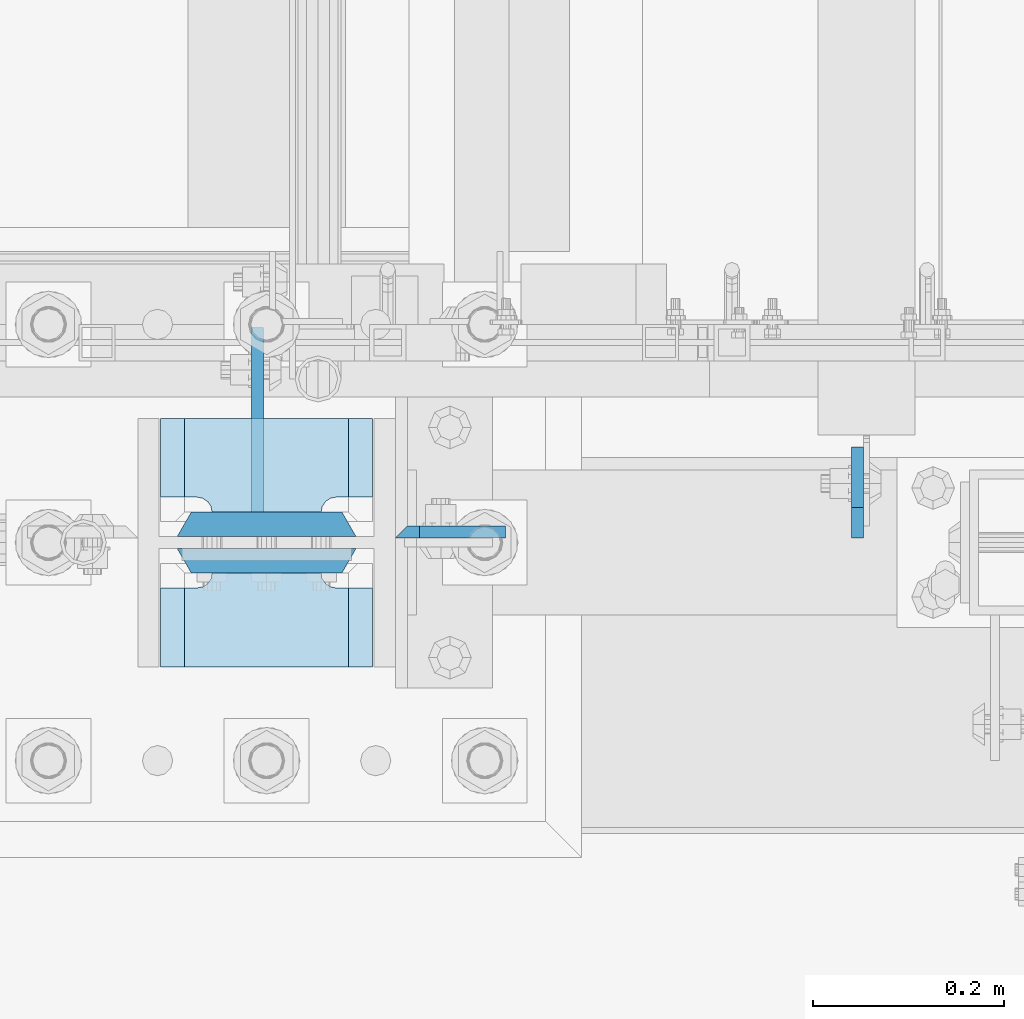
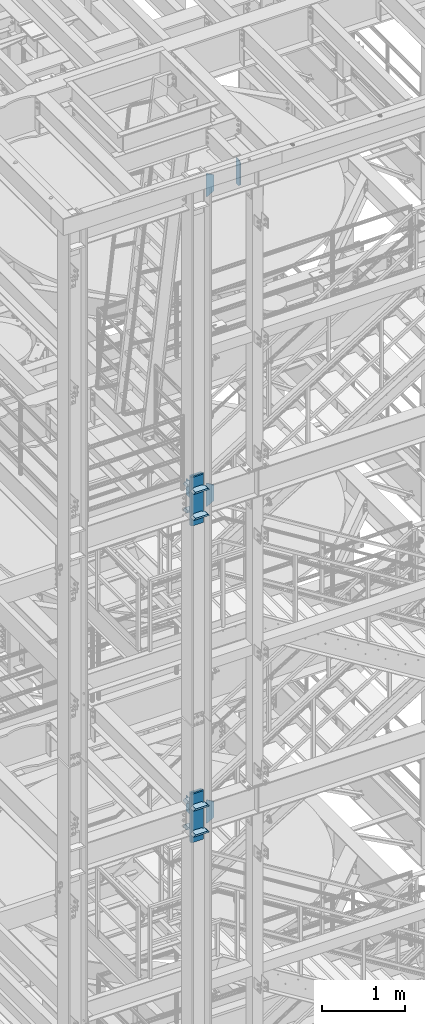
# One storey, part 1435 of 1876: 18 plates, 3 elements without a shape of their own.
"""IFC2X3 building model written with IfcOpenShell, lengths in millimetres."""

from ifc_helpers import new_model, si_unit, frame, origin_with_axes, place, context, subcontext, project, spatial, faceted_brep, material, type_object, element, aggregate, save


model = new_model("IFC2X3")

# Units and contexts
model_context = context("Model", 3, precision=1e-05, world=origin_with_axes())
body_context = subcontext(model_context, "Body", "Model", "MODEL_VIEW")
ifc_project = project(units=[si_unit("LENGTHUNIT", "METRE", prefix="MILLI"), si_unit("AREAUNIT", "SQUARE_METRE"), si_unit("VOLUMEUNIT", "CUBIC_METRE"), si_unit("MASSUNIT", "GRAM", prefix="KILO"), si_unit("TIMEUNIT", "SECOND"), si_unit("PLANEANGLEUNIT", "RADIAN"), si_unit("SOLIDANGLEUNIT", "STERADIAN"), si_unit("THERMODYNAMICTEMPERATUREUNIT", "DEGREE_CELSIUS"), si_unit("LUMINOUSINTENSITYUNIT", "LUMEN")], contexts=[model_context])

# Site, building, storey
site_placement = place(None, origin_with_axes())
site = spatial("IfcSite", under=ifc_project, at=site_placement, CompositionType="ELEMENT")
building_placement = place(site_placement, origin_with_axes())
building = spatial("IfcBuilding", under=site, at=building_placement, Name="Undefined", CompositionType="ELEMENT")
storey_placement = place(building_placement, origin_with_axes())
storey = spatial("IfcBuildingStorey", under=building, at=storey_placement, Name="Undefined", CompositionType="ELEMENT", Elevation=0.0)

# Assembly, plates
assembly_1_placement = place(storey_placement, origin_with_axes())
assembly_1 = element("IfcElementAssembly", 1, at=assembly_1_placement, inside=storey, Name="COLUMN", AssemblyPlace="NOTDEFINED", PredefinedType="RIGID_FRAME")
ifc_material_1 = material(Name="STEEL/A572-50")
plate_type_1 = type_object("IfcPlateType", PredefinedType="NOTDEFINED")
plate_1_placement = place(assembly_1_placement, frame((1862.1375, -7100.88799991608, 17946.6875), z_axis=(1.0, 0.0, 0.0), x_axis=(0.0, 0.0, -1.0)))
plate_1 = element("IfcPlate", 2, at=plate_1_placement, type_object=plate_type_1, material=ifc_material_1, Name="PLATE", context=body_context, shape_type="Brep", body=[
    faceted_brep([(0.0, -6.35000000000036, 0.0), (-1.06936913171421e-12, 6.34999999999945, 12.699999332428), (336.549987792969, 6.35000000000036, 12.7), (336.549987792969, -6.35000000000036, 0.0), (336.550000000001, -6.35000000000036, 25.4000000000005), (336.549987792969, 6.35000000000036, 25.4000000000005), (284.53616791736, 6.35000000000036, 115.490600585938), (284.53616791736, -6.35000000000036, 115.490600307004), (52.0138320922852, -6.35000000000036, 115.490599060059), (52.0138320922852, 6.35000000000036, 115.490600585938), (0.0, 6.35000000000036, 25.4000000000005), (0.0, -6.35000000000036, 25.4000000000005)], [[[0, 1, 2, 3]], [[4, 5, 6, 7]], [[8, 9, 10, 11]], [[11, 10, 1, 0]], [[8, 11, 0, 3, 4, 7]], [[9, 8, 7, 6]], [[10, 9, 6, 5, 2, 1]], [[5, 4, 3, 2]]]),
])
plate_2_placement = place(assembly_1_placement, frame((1862.1375, -7100.88799991608, 22518.6875), z_axis=(1.0, 0.0, 0.0), x_axis=(0.0, 0.0, -1.0)))
plate_2 = element("IfcPlate", 3, at=plate_2_placement, type_object=plate_type_1, material=ifc_material_1, Name="PLATE", context=body_context, shape_type="Brep", body=[
    faceted_brep([(0.0, -6.35000000000036, 0.0), (-1.06936913171421e-12, 6.34999999999945, 12.699999332428), (336.549987792969, 6.35000000000036, 12.7), (336.549987792969, -6.35000000000036, 0.0), (336.550000000001, -6.35000000000036, 25.4000000000005), (336.549987792969, 6.35000000000036, 25.4000000000005), (284.53616791736, 6.35000000000036, 115.490600585938), (284.53616791736, -6.35000000000036, 115.490600307004), (52.0138320922852, -6.35000000000036, 115.490599060059), (52.0138320922852, 6.35000000000036, 115.490600585938), (0.0, 6.35000000000036, 25.4000000000005), (0.0, -6.35000000000036, 25.4000000000005)], [[[0, 1, 2, 3]], [[4, 5, 6, 7]], [[8, 9, 10, 11]], [[11, 10, 1, 0]], [[8, 11, 0, 3, 4, 7]], [[9, 8, 7, 6]], [[10, 9, 6, 5, 2, 1]], [[5, 4, 3, 2]]]),
])

# Assembly, plate
assembly_2_placement = place(storey_placement, origin_with_axes())
assembly_2 = element("IfcElementAssembly", 4, at=assembly_2_placement, inside=storey, Name="COLUMN", AssemblyPlace="NOTDEFINED", PredefinedType="RIGID_FRAME")
plate_3_placement = place(assembly_2_placement, frame((1862.1375, -7100.88799991608, 13273.0875), z_axis=(1.0, 0.0, 0.0), x_axis=(0.0, 0.0, -1.0)))
plate_3 = element("IfcPlate", 5, at=plate_3_placement, type_object=plate_type_1, material=ifc_material_1, Name="PLATE", context=body_context, shape_type="Brep", body=[
    faceted_brep([(0.0, -6.35000000000036, 0.0), (-1.06936913171421e-12, 6.34999999999945, 12.699999332428), (336.549987792969, 6.35000000000036, 12.7), (336.549987792969, -6.35000000000036, 0.0), (336.550000000001, -6.35000000000036, 25.4000000000005), (336.549987792969, 6.35000000000036, 25.4000000000005), (284.53616791736, 6.35000000000036, 115.490600585938), (284.53616791736, -6.35000000000036, 115.490600307004), (52.0138320922852, -6.35000000000036, 115.490599060059), (52.0138320922852, 6.35000000000036, 115.490600585938), (0.0, 6.35000000000036, 25.4000000000005), (0.0, -6.35000000000036, 25.4000000000005)], [[[0, 1, 2, 3]], [[4, 5, 6, 7]], [[8, 9, 10, 11]], [[11, 10, 1, 0]], [[8, 11, 0, 3, 4, 7]], [[9, 8, 7, 6]], [[10, 9, 6, 5, 2, 1]], [[5, 4, 3, 2]]]),
])

assembly_3_placement = place(storey_placement, origin_with_axes())
assembly_3 = element("IfcElementAssembly", 6, at=assembly_3_placement, inside=storey, Name="BEAM", AssemblyPlace="NOTDEFINED", PredefinedType="RIGID_FRAME")
ifc_material_2 = material(Name="STEEL/A36")
plate_type_2 = type_object("IfcPlateType", PredefinedType="NOTDEFINED")
plate_4_placement = place(assembly_3_placement, frame((2346.32499990463, -7107.2375, 22161.5), z_axis=(0.0, 0.0, 1.0), x_axis=(0.0, 1.0, 0.0)))
plate_4 = element("IfcPlate", 7, at=plate_4_placement, type_object=plate_type_2, material=ifc_material_2, Name="PLATE", context=body_context, shape_type="Brep", body=[
    faceted_brep([(0.0, -6.34999999999991, 31.75), (9.09494701772928e-13, -6.35000000000036, 347.662506103516), (-9.09494701772928e-13, 6.35000000000036, 347.662506103516), (0.0, 6.34999999999991, 31.75), (31.7500000000055, -6.35000000000036, 379.412506103516), (31.7500000000055, 6.35000000000036, 379.412506103516), (95.25, -6.35000000000036, 379.412506103516), (95.25, 6.35000000000036, 379.412506103516), (95.25, -6.35000000000036, 0.0), (95.25, 6.35000000000036, 0.0), (31.75, -6.34999999999991, 0.0), (31.75, 6.34999999999991, 0.0)], [[[0, 1, 2, 3]], [[1, 4, 5, 2]], [[4, 6, 7, 5]], [[6, 8, 9, 7]], [[8, 10, 11, 9]], [[10, 0, 3, 11]], [[5, 7, 9, 11, 3, 2]], [[10, 8, 6, 4, 1, 0]]]),
])
aggregate(assembly_3, [plate_4])

# Plate
ifc_material_3 = material(Name="STEEL/A572-GR.50")
plate_type_3 = type_object("IfcPlateType", PredefinedType="NOTDEFINED")
plate_5_placement = place(assembly_1_placement, frame((1838.325, -7143.75, 17586.3249933287), z_axis=(-1.0, 0.0, 0.0), x_axis=(0.0, -1.0, 0.0)))
plate_5 = element("IfcPlate", 8, at=plate_5_placement, type_object=plate_type_3, material=ifc_material_3, Name="PLATE", context=body_context, shape_type="Brep", body=[
    faceted_brep([(98.4250030517578, -12.7000000000007, 222.25), (98.4250030517578, 12.7000000000007, 197.150000002177), (15.875, 12.7000000000007, 197.150000002177), (15.875, -12.7000000000007, 222.25), (14.6665875786157, -12.7000000000007, 178.074902037082), (15.875, -12.7000000000007, 184.150001525879), (15.875, 12.7000000000007, 184.150001525879), (14.6665875786157, 12.7000000000007, 178.074902037082), (11.2253201513358, -12.7000000000007, 172.924681374541), (11.2253201513358, 12.7000000000007, 172.924681374541), (6.07509948879488, -12.7000000000007, 169.483413947261), (6.07509948879488, 12.7000000000007, 169.483413947261), (0.0, -12.7000000000007, 168.275001525879), (0.0, 12.7000000000007, 168.275001525879), (0.0, -12.7000000000007, 53.9749984741211), (0.0, 12.7000000000007, 53.9749984741211), (6.07509948879579, -12.7000000000007, 52.7665860527377), (6.07509948879579, 12.7000000000007, 52.7665860527377), (11.2253201513367, -12.7000000000007, 49.3253186254576), (11.2253201513367, 12.7000000000007, 49.3253186254576), (14.6665875786166, -12.7000000000007, 44.1750979629169), (14.6665875786166, 12.7000000000007, 44.1750979629169), (15.875, -12.7000000000007, 38.0999984741211), (15.875, 12.7000000000007, 38.0999984741211), (15.875, 12.7000000000007, 25.0999999978233), (15.875, -12.7000000000007, 0.0), (98.4250030517578, 12.7000000000007, 25.0999999978233), (98.4250030517578, -12.7000000000007, 0.0)], [[[0, 1, 2, 3]], [[4, 5, 6, 7]], [[8, 4, 7, 9]], [[10, 8, 9, 11]], [[12, 10, 11, 13]], [[14, 12, 13, 15]], [[16, 14, 15, 17]], [[18, 16, 17, 19]], [[20, 18, 19, 21]], [[22, 20, 21, 23]], [[22, 23, 24, 25]], [[26, 27, 25, 24]], [[5, 4, 8, 10, 12, 14, 16, 18, 20, 22, 25, 27, 0, 3]], [[6, 5, 3, 2]], [[26, 24, 23, 21, 19, 17, 15, 13, 11, 9, 7, 6, 2, 1]], [[27, 26, 1, 0]]]),
])

plate_6_placement = place(assembly_1_placement, frame((1838.325, -7143.75, 17970.4999994323), z_axis=(-1.0, 0.0, 0.0), x_axis=(0.0, -1.0, 0.0)))
plate_6 = element("IfcPlate", 9, at=plate_6_placement, type_object=plate_type_3, material=ifc_material_3, Name="PLATE", context=body_context, shape_type="Brep", body=[
    faceted_brep([(98.4250030517578, -12.7000000000007, 222.25), (98.4250030517578, 12.7000000000007, 197.150000002177), (15.875, 12.7000000000007, 197.150000002177), (15.875, -12.7000000000007, 222.25), (14.6665875786157, -12.7000000000007, 178.074902037082), (15.875, -12.7000000000007, 184.150001525879), (15.875, 12.7000000000007, 184.150001525879), (14.6665875786157, 12.7000000000007, 178.074902037082), (11.2253201513358, -12.7000000000007, 172.924681374541), (11.2253201513358, 12.7000000000007, 172.924681374541), (6.07509948879488, -12.7000000000007, 169.483413947261), (6.07509948879488, 12.7000000000007, 169.483413947261), (0.0, -12.7000000000007, 168.275001525879), (0.0, 12.7000000000007, 168.275001525879), (0.0, -12.7000000000007, 53.9749984741211), (0.0, 12.7000000000007, 53.9749984741211), (6.07509948879579, -12.7000000000007, 52.7665860527377), (6.07509948879579, 12.7000000000007, 52.7665860527377), (11.2253201513367, -12.7000000000007, 49.3253186254576), (11.2253201513367, 12.7000000000007, 49.3253186254576), (14.6665875786166, -12.7000000000007, 44.1750979629169), (14.6665875786166, 12.7000000000007, 44.1750979629169), (15.875, -12.7000000000007, 38.0999984741211), (15.875, 12.7000000000007, 38.0999984741211), (15.875, 12.7000000000007, 25.0999999978233), (15.875, -12.7000000000007, 0.0), (98.4250030517578, 12.7000000000007, 25.0999999978233), (98.4250030517578, -12.7000000000007, 0.0)], [[[0, 1, 2, 3]], [[4, 5, 6, 7]], [[8, 4, 7, 9]], [[10, 8, 9, 11]], [[12, 10, 11, 13]], [[14, 12, 13, 15]], [[16, 14, 15, 17]], [[18, 16, 17, 19]], [[20, 18, 19, 21]], [[22, 20, 21, 23]], [[22, 23, 24, 25]], [[26, 27, 25, 24]], [[5, 4, 8, 10, 12, 14, 16, 18, 20, 22, 25, 27, 0, 3]], [[6, 5, 3, 2]], [[26, 24, 23, 21, 19, 17, 15, 13, 11, 9, 7, 6, 2, 1]], [[27, 26, 1, 0]]]),
])

plate_7_placement = place(assembly_1_placement, frame((1838.325, -6981.825, 17586.3249933287), z_axis=(-1.0, 0.0, 0.0), x_axis=(0.0, -1.0, 0.0)))
plate_7 = element("IfcPlate", 10, at=plate_7_placement, type_object=plate_type_3, material=ifc_material_3, Name="PLATE", context=body_context, shape_type="Brep", body=[
    faceted_brep([(82.5500030517578, -12.7000000000007, 222.25), (82.5500030517578, 12.7000000000007, 197.150000002177), (0.0, 12.7000000000007, 197.150000002177), (0.0, -12.7000000000007, 222.25), (82.5500030517578, 12.7000000000007, 25.0999999978233), (82.5500030517578, -12.7000000000007, 0.0), (0.0, -12.6999999999998, 0.0), (0.0, 12.7000000000007, 25.0999999978233), (82.5500030517578, 12.7000000000007, 38.0999984741211), (82.5500030517578, -12.7000000000007, 38.0999984741211), (83.7584154731412, -12.7000000000007, 44.1750979629169), (83.7584154731412, 12.7000000000007, 44.1750979629169), (87.1996829004211, -12.7000000000007, 49.3253186254576), (87.1996829004211, 12.7000000000007, 49.3253186254576), (92.349903562962, -12.7000000000007, 52.7665860527377), (92.349903562962, 12.7000000000007, 52.7665860527377), (98.4250030517578, -12.7000000000007, 53.9749984741211), (98.4250030517578, 12.7000000000007, 53.9749984741211), (98.4250030517578, -12.7000000000007, 168.275001525879), (98.4250030517578, 12.7000000000007, 168.275001525879), (92.349903562962, -12.7000000000007, 169.483413947262), (92.349903562962, 12.7000000000007, 169.483413947262), (87.1996829004211, -12.7000000000007, 172.924681374543), (87.1996829004211, 12.7000000000007, 172.924681374543), (83.7584154731412, -12.7000000000007, 178.074902037083), (83.7584154731412, 12.7000000000007, 178.074902037083), (82.5500030517578, -12.7000000000007, 184.150001525879), (82.5500030517578, 12.7000000000007, 184.150001525879)], [[[0, 1, 2, 3]], [[4, 5, 6, 7]], [[8, 9, 5, 4]], [[10, 9, 8, 11]], [[12, 10, 11, 13]], [[14, 12, 13, 15]], [[16, 14, 15, 17]], [[18, 16, 17, 19]], [[20, 18, 19, 21]], [[22, 20, 21, 23]], [[24, 22, 23, 25]], [[26, 24, 25, 27]], [[6, 5, 9, 10, 12, 14, 16, 18, 20, 22, 24, 26, 0, 3]], [[7, 6, 3, 2]], [[27, 25, 23, 21, 19, 17, 15, 13, 11, 8, 4, 7, 2, 1]], [[26, 27, 1, 0]]]),
])

plate_8_placement = place(assembly_1_placement, frame((1838.325, -6981.825, 17970.4999994323), z_axis=(-1.0, 0.0, 0.0), x_axis=(0.0, -1.0, 0.0)))
plate_8 = element("IfcPlate", 11, at=plate_8_placement, type_object=plate_type_3, material=ifc_material_3, Name="PLATE", context=body_context, shape_type="Brep", body=[
    faceted_brep([(82.5500030517578, -12.7000000000007, 222.25), (82.5500030517578, 12.7000000000007, 197.150000002177), (0.0, 12.7000000000007, 197.150000002177), (0.0, -12.7000000000007, 222.25), (82.5500030517578, 12.7000000000007, 25.0999999978233), (82.5500030517578, -12.7000000000007, 0.0), (0.0, -12.6999999999998, 0.0), (0.0, 12.7000000000007, 25.0999999978233), (82.5500030517578, 12.7000000000007, 38.0999984741211), (82.5500030517578, -12.7000000000007, 38.0999984741211), (83.7584154731412, -12.7000000000007, 44.1750979629169), (83.7584154731412, 12.7000000000007, 44.1750979629169), (87.1996829004211, -12.7000000000007, 49.3253186254576), (87.1996829004211, 12.7000000000007, 49.3253186254576), (92.349903562962, -12.7000000000007, 52.7665860527377), (92.349903562962, 12.7000000000007, 52.7665860527377), (98.4250030517578, -12.7000000000007, 53.9749984741211), (98.4250030517578, 12.7000000000007, 53.9749984741211), (98.4250030517578, -12.7000000000007, 168.275001525879), (98.4250030517578, 12.7000000000007, 168.275001525879), (92.349903562962, -12.7000000000007, 169.483413947262), (92.349903562962, 12.7000000000007, 169.483413947262), (87.1996829004211, -12.7000000000007, 172.924681374543), (87.1996829004211, 12.7000000000007, 172.924681374543), (83.7584154731412, -12.7000000000007, 178.074902037083), (83.7584154731412, 12.7000000000007, 178.074902037083), (82.5500030517578, -12.7000000000007, 184.150001525879), (82.5500030517578, 12.7000000000007, 184.150001525879)], [[[0, 1, 2, 3]], [[4, 5, 6, 7]], [[8, 9, 5, 4]], [[10, 9, 8, 11]], [[12, 10, 11, 13]], [[14, 12, 13, 15]], [[16, 14, 15, 17]], [[18, 16, 17, 19]], [[20, 18, 19, 21]], [[22, 20, 21, 23]], [[24, 22, 23, 25]], [[26, 24, 25, 27]], [[6, 5, 9, 10, 12, 14, 16, 18, 20, 22, 24, 26, 0, 3]], [[7, 6, 3, 2]], [[27, 25, 23, 21, 19, 17, 15, 13, 11, 8, 4, 7, 2, 1]], [[26, 27, 1, 0]]]),
])

plate_9_placement = place(assembly_2_placement, frame((1838.325, -7143.75, 12912.7249938965), z_axis=(-1.0, 0.0, 0.0), x_axis=(0.0, -1.0, 0.0)))
plate_9 = element("IfcPlate", 12, at=plate_9_placement, type_object=plate_type_3, material=ifc_material_3, Name="PLATE", context=body_context, shape_type="Brep", body=[
    faceted_brep([(98.4250030517578, -12.7000000000007, 222.25), (98.4250030517578, 12.7000000000007, 197.150000002177), (15.875, 12.7000000000007, 197.150000002177), (15.875, -12.7000000000007, 222.25), (14.6665875786157, -12.7000000000007, 178.074902037082), (15.875, -12.7000000000007, 184.150001525879), (15.875, 12.7000000000007, 184.150001525879), (14.6665875786157, 12.7000000000007, 178.074902037082), (11.2253201513358, -12.7000000000007, 172.924681374541), (11.2253201513358, 12.7000000000007, 172.924681374541), (6.07509948879488, -12.7000000000007, 169.483413947261), (6.07509948879488, 12.7000000000007, 169.483413947261), (0.0, -12.7000000000007, 168.275001525879), (0.0, 12.7000000000007, 168.275001525879), (0.0, -12.7000000000007, 53.9749984741211), (0.0, 12.7000000000007, 53.9749984741211), (6.07509948879579, -12.7000000000007, 52.7665860527377), (6.07509948879579, 12.7000000000007, 52.7665860527377), (11.2253201513367, -12.7000000000007, 49.3253186254576), (11.2253201513367, 12.7000000000007, 49.3253186254576), (14.6665875786166, -12.7000000000007, 44.1750979629169), (14.6665875786166, 12.7000000000007, 44.1750979629169), (15.875, -12.7000000000007, 38.0999984741211), (15.875, 12.7000000000007, 38.0999984741211), (15.875, 12.7000000000007, 25.0999999978233), (15.875, -12.7000000000007, 0.0), (98.4250030517578, 12.7000000000007, 25.0999999978233), (98.4250030517578, -12.7000000000007, 0.0)], [[[0, 1, 2, 3]], [[4, 5, 6, 7]], [[8, 4, 7, 9]], [[10, 8, 9, 11]], [[12, 10, 11, 13]], [[14, 12, 13, 15]], [[16, 14, 15, 17]], [[18, 16, 17, 19]], [[20, 18, 19, 21]], [[22, 20, 21, 23]], [[22, 23, 24, 25]], [[26, 27, 25, 24]], [[5, 4, 8, 10, 12, 14, 16, 18, 20, 22, 25, 27, 0, 3]], [[6, 5, 3, 2]], [[26, 24, 23, 21, 19, 17, 15, 13, 11, 9, 7, 6, 2, 1]], [[27, 26, 1, 0]]]),
])

plate_10_placement = place(assembly_2_placement, frame((1838.325, -7143.75, 13296.9), z_axis=(-1.0, 0.0, 0.0), x_axis=(0.0, -1.0, 0.0)))
plate_10 = element("IfcPlate", 13, at=plate_10_placement, type_object=plate_type_3, material=ifc_material_3, Name="PLATE", context=body_context, shape_type="Brep", body=[
    faceted_brep([(98.4250030517578, -12.7000000000007, 222.25), (98.4250030517578, 12.7000000000007, 197.150000002177), (15.875, 12.7000000000007, 197.150000002177), (15.875, -12.7000000000007, 222.25), (14.6665875786157, -12.7000000000007, 178.074902037082), (15.875, -12.7000000000007, 184.150001525879), (15.875, 12.7000000000007, 184.150001525879), (14.6665875786157, 12.7000000000007, 178.074902037082), (11.2253201513358, -12.7000000000007, 172.924681374541), (11.2253201513358, 12.7000000000007, 172.924681374541), (6.07509948879488, -12.7000000000007, 169.483413947261), (6.07509948879488, 12.7000000000007, 169.483413947261), (0.0, -12.7000000000007, 168.275001525879), (0.0, 12.7000000000007, 168.275001525879), (0.0, -12.7000000000007, 53.9749984741211), (0.0, 12.7000000000007, 53.9749984741211), (6.07509948879579, -12.7000000000007, 52.7665860527377), (6.07509948879579, 12.7000000000007, 52.7665860527377), (11.2253201513367, -12.7000000000007, 49.3253186254576), (11.2253201513367, 12.7000000000007, 49.3253186254576), (14.6665875786166, -12.7000000000007, 44.1750979629169), (14.6665875786166, 12.7000000000007, 44.1750979629169), (15.875, -12.7000000000007, 38.0999984741211), (15.875, 12.7000000000007, 38.0999984741211), (15.875, 12.7000000000007, 25.0999999978233), (15.875, -12.7000000000007, 0.0), (98.4250030517578, 12.7000000000007, 25.0999999978233), (98.4250030517578, -12.7000000000007, 0.0)], [[[0, 1, 2, 3]], [[4, 5, 6, 7]], [[8, 4, 7, 9]], [[10, 8, 9, 11]], [[12, 10, 11, 13]], [[14, 12, 13, 15]], [[16, 14, 15, 17]], [[18, 16, 17, 19]], [[20, 18, 19, 21]], [[22, 20, 21, 23]], [[22, 23, 24, 25]], [[26, 27, 25, 24]], [[5, 4, 8, 10, 12, 14, 16, 18, 20, 22, 25, 27, 0, 3]], [[6, 5, 3, 2]], [[26, 24, 23, 21, 19, 17, 15, 13, 11, 9, 7, 6, 2, 1]], [[27, 26, 1, 0]]]),
])

plate_11_placement = place(assembly_2_placement, frame((1838.325, -6981.825, 12912.7249938965), z_axis=(-1.0, 0.0, 0.0), x_axis=(0.0, -1.0, 0.0)))
plate_11 = element("IfcPlate", 14, at=plate_11_placement, type_object=plate_type_3, material=ifc_material_3, Name="PLATE", context=body_context, shape_type="Brep", body=[
    faceted_brep([(82.5500030517578, -12.7000000000007, 222.25), (82.5500030517578, 12.7000000000007, 197.150000002177), (0.0, 12.7000000000007, 197.150000002177), (0.0, -12.7000000000007, 222.25), (82.5500030517578, 12.7000000000007, 25.0999999978233), (82.5500030517578, -12.7000000000007, 0.0), (0.0, -12.6999999999998, 0.0), (0.0, 12.7000000000007, 25.0999999978233), (82.5500030517578, 12.7000000000007, 38.0999984741211), (82.5500030517578, -12.7000000000007, 38.0999984741211), (83.7584154731412, -12.7000000000007, 44.1750979629169), (83.7584154731412, 12.7000000000007, 44.1750979629169), (87.1996829004211, -12.7000000000007, 49.3253186254576), (87.1996829004211, 12.7000000000007, 49.3253186254576), (92.349903562962, -12.7000000000007, 52.7665860527377), (92.349903562962, 12.7000000000007, 52.7665860527377), (98.4250030517578, -12.7000000000007, 53.9749984741211), (98.4250030517578, 12.7000000000007, 53.9749984741211), (98.4250030517578, -12.7000000000007, 168.275001525879), (98.4250030517578, 12.7000000000007, 168.275001525879), (92.349903562962, -12.7000000000007, 169.483413947262), (92.349903562962, 12.7000000000007, 169.483413947262), (87.1996829004211, -12.7000000000007, 172.924681374543), (87.1996829004211, 12.7000000000007, 172.924681374543), (83.7584154731412, -12.7000000000007, 178.074902037083), (83.7584154731412, 12.7000000000007, 178.074902037083), (82.5500030517578, -12.7000000000007, 184.150001525879), (82.5500030517578, 12.7000000000007, 184.150001525879)], [[[0, 1, 2, 3]], [[4, 5, 6, 7]], [[8, 9, 5, 4]], [[10, 9, 8, 11]], [[12, 10, 11, 13]], [[14, 12, 13, 15]], [[16, 14, 15, 17]], [[18, 16, 17, 19]], [[20, 18, 19, 21]], [[22, 20, 21, 23]], [[24, 22, 23, 25]], [[26, 24, 25, 27]], [[6, 5, 9, 10, 12, 14, 16, 18, 20, 22, 24, 26, 0, 3]], [[7, 6, 3, 2]], [[27, 25, 23, 21, 19, 17, 15, 13, 11, 8, 4, 7, 2, 1]], [[26, 27, 1, 0]]]),
])

plate_12_placement = place(assembly_2_placement, frame((1838.325, -6981.825, 13296.9), z_axis=(-1.0, 0.0, 0.0), x_axis=(0.0, -1.0, 0.0)))
plate_12 = element("IfcPlate", 15, at=plate_12_placement, type_object=plate_type_3, material=ifc_material_3, Name="PLATE", context=body_context, shape_type="Brep", body=[
    faceted_brep([(82.5500030517578, -12.7000000000007, 222.25), (82.5500030517578, 12.7000000000007, 197.150000002177), (0.0, 12.7000000000007, 197.150000002177), (0.0, -12.7000000000007, 222.25), (82.5500030517578, 12.7000000000007, 25.0999999978233), (82.5500030517578, -12.7000000000007, 0.0), (0.0, -12.6999999999998, 0.0), (0.0, 12.7000000000007, 25.0999999978233), (82.5500030517578, 12.7000000000007, 38.0999984741211), (82.5500030517578, -12.7000000000007, 38.0999984741211), (83.7584154731412, -12.7000000000007, 44.1750979629169), (83.7584154731412, 12.7000000000007, 44.1750979629169), (87.1996829004211, -12.7000000000007, 49.3253186254576), (87.1996829004211, 12.7000000000007, 49.3253186254576), (92.349903562962, -12.7000000000007, 52.7665860527377), (92.349903562962, 12.7000000000007, 52.7665860527377), (98.4250030517578, -12.7000000000007, 53.9749984741211), (98.4250030517578, 12.7000000000007, 53.9749984741211), (98.4250030517578, -12.7000000000007, 168.275001525879), (98.4250030517578, 12.7000000000007, 168.275001525879), (92.349903562962, -12.7000000000007, 169.483413947262), (92.349903562962, 12.7000000000007, 169.483413947262), (87.1996829004211, -12.7000000000007, 172.924681374543), (87.1996829004211, 12.7000000000007, 172.924681374543), (83.7584154731412, -12.7000000000007, 178.074902037083), (83.7584154731412, 12.7000000000007, 178.074902037083), (82.5500030517578, -12.7000000000007, 184.150001525879), (82.5500030517578, 12.7000000000007, 184.150001525879)], [[[0, 1, 2, 3]], [[4, 5, 6, 7]], [[8, 9, 5, 4]], [[10, 9, 8, 11]], [[12, 10, 11, 13]], [[14, 12, 13, 15]], [[16, 14, 15, 17]], [[18, 16, 17, 19]], [[20, 18, 19, 21]], [[22, 20, 21, 23]], [[24, 22, 23, 25]], [[26, 24, 25, 27]], [[6, 5, 9, 10, 12, 14, 16, 18, 20, 22, 24, 26, 0, 3]], [[7, 6, 3, 2]], [[27, 25, 23, 21, 19, 17, 15, 13, 11, 8, 4, 7, 2, 1]], [[26, 27, 1, 0]]]),
])

plate_type_4 = type_object("IfcPlateType", PredefinedType="NOTDEFINED")
plate_13_placement = place(assembly_1_placement, frame((1633.5375, -7131.05, 18135.6), z_axis=(1.0, 0.0, 0.0), x_axis=(0.0, 0.0, -1.0)))
plate_13 = element("IfcPlate", 16, at=plate_13_placement, type_object=plate_type_4, material=ifc_material_3, Name="PLATE", context=body_context, shape_type="Brep", body=[
    faceted_brep([(0.0, -12.6999999999998, 172.660303166218), (714.375, -12.6999999999998, 172.660303166232), (714.375, 12.6999999999998, 187.324996948242), (0.0, 12.6999999999998, 187.324996948242), (714.375, -12.6999999999998, 14.6646968337647), (714.375, 12.6999999999998, 0.0), (0.0, 12.6999999999998, 0.0), (0.0, -12.6999999999998, 14.6646968337648)], [[[0, 1, 2, 3]], [[2, 1, 4, 5]], [[3, 2, 5, 6]], [[0, 3, 6, 7]], [[1, 0, 7, 4]], [[6, 5, 4, 7]]]),
])

plate_14_placement = place(assembly_1_placement, frame((1633.5375, -7092.95, 18135.6), z_axis=(1.0, 0.0, 0.0), x_axis=(0.0, 0.0, -1.0)))
plate_14 = element("IfcPlate", 17, at=plate_14_placement, type_object=plate_type_4, material=ifc_material_3, Name="PLATE", context=body_context, shape_type="Brep", body=[
    faceted_brep([(0.0, 12.6999999999998, 172.66030316161), (0.0, -12.6999999999998, 187.324996948242), (714.375, -12.6999999999998, 187.324996948242), (714.375, 12.6999999999998, 172.660303161603), (714.375, 12.6999999999998, 14.6646968384017), (0.0, 12.6999999999998, 14.6646968383725), (0.0, -12.6999999999998, 0.0), (714.375, -12.6999999999998, 0.0)], [[[0, 1, 2, 3]], [[0, 3, 4, 5]], [[1, 0, 5, 6]], [[2, 1, 6, 7]], [[3, 2, 7, 4]], [[6, 5, 4, 7]]]),
])

plate_15_placement = place(assembly_2_placement, frame((1633.5375, -7131.05, 13462.0), z_axis=(1.0, 0.0, 0.0), x_axis=(0.0, 0.0, -1.0)))
plate_15 = element("IfcPlate", 18, at=plate_15_placement, type_object=plate_type_4, material=ifc_material_3, Name="PLATE", context=body_context, shape_type="Brep", body=[
    faceted_brep([(0.0, -12.6999999999998, 172.660303166218), (714.375, -12.6999999999998, 172.660303166232), (714.375, 12.6999999999998, 187.324996948242), (0.0, 12.6999999999998, 187.324996948242), (714.375, -12.6999999999998, 14.6646968337647), (714.375, 12.6999999999998, 0.0), (0.0, 12.6999999999998, 0.0), (0.0, -12.6999999999998, 14.6646968337648)], [[[0, 1, 2, 3]], [[2, 1, 4, 5]], [[3, 2, 5, 6]], [[0, 3, 6, 7]], [[1, 0, 7, 4]], [[6, 5, 4, 7]]]),
])

plate_16_placement = place(assembly_2_placement, frame((1633.5375, -7092.95, 13462.0), z_axis=(1.0, 0.0, 0.0), x_axis=(0.0, 0.0, -1.0)))
plate_16 = element("IfcPlate", 19, at=plate_16_placement, type_object=plate_type_4, material=ifc_material_3, Name="PLATE", context=body_context, shape_type="Brep", body=[
    faceted_brep([(0.0, 12.6999999999998, 172.66030316161), (0.0, -12.6999999999998, 187.324996948242), (714.375, -12.6999999999998, 187.324996948242), (714.375, 12.6999999999998, 172.660303161603), (714.375, 12.6999999999998, 14.6646968384017), (0.0, 12.6999999999998, 14.6646968383725), (0.0, -12.6999999999998, 0.0), (714.375, -12.6999999999998, 0.0)], [[[0, 1, 2, 3]], [[0, 3, 4, 5]], [[1, 0, 5, 6]], [[2, 1, 6, 7]], [[3, 2, 7, 4]], [[6, 5, 4, 7]]]),
])

plate_type_5 = type_object("IfcPlateType", PredefinedType="NOTDEFINED")
plate_17_placement = place(assembly_1_placement, frame((1717.67500004768, -7080.25, 17945.0999994323), z_axis=(0.0, 1.0, 0.0), x_axis=(0.0, 0.0, -1.0)))
plate_17 = element("IfcPlate", 20, at=plate_17_placement, type_object=plate_type_5, material=ifc_material_1, Name="PLATE", context=body_context, shape_type="Brep", body=[
    faceted_brep([(0.0, -6.35000000000036, 0.0), (0.0, -6.34999999999991, 193.675003051758), (0.0, 6.34999999999991, 193.675003051758), (0.0, 6.35000000000036, 0.0), (228.600006103516, -6.34999999999991, 193.675003051758), (228.600006103516, 6.34999999999991, 193.675003051758), (228.600006103516, -6.34999999999854, 0.0), (228.600006103516, 6.34999999999854, 0.0)], [[[0, 1, 2, 3]], [[1, 4, 5, 2]], [[4, 6, 7, 5]], [[6, 0, 3, 7]], [[5, 7, 3, 2]], [[6, 4, 1, 0]]]),
])

aggregate(assembly_1, [plate_5, plate_6, plate_7, plate_8, plate_13, plate_14, plate_17, plate_1, plate_2])

plate_18_placement = place(assembly_2_placement, frame((1717.67500004768, -7080.25, 13271.5), z_axis=(0.0, 1.0, 0.0), x_axis=(0.0, 0.0, -1.0)))
plate_18 = element("IfcPlate", 21, at=plate_18_placement, type_object=plate_type_5, material=ifc_material_1, Name="PLATE", context=body_context, shape_type="Brep", body=[
    faceted_brep([(0.0, -6.35000000000036, 0.0), (0.0, -6.34999999999991, 193.675003051758), (0.0, 6.34999999999991, 193.675003051758), (0.0, 6.35000000000036, 0.0), (228.600006103516, -6.34999999999991, 193.675003051758), (228.600006103516, 6.34999999999991, 193.675003051758), (228.600006103516, -6.34999999999854, 0.0), (228.600006103516, 6.34999999999854, 0.0)], [[[0, 1, 2, 3]], [[1, 4, 5, 2]], [[4, 6, 7, 5]], [[6, 0, 3, 7]], [[5, 7, 3, 2]], [[6, 4, 1, 0]]]),
])

aggregate(assembly_2, [plate_9, plate_10, plate_11, plate_12, plate_15, plate_16, plate_18, plate_3])

save(model, "model.ifc")
